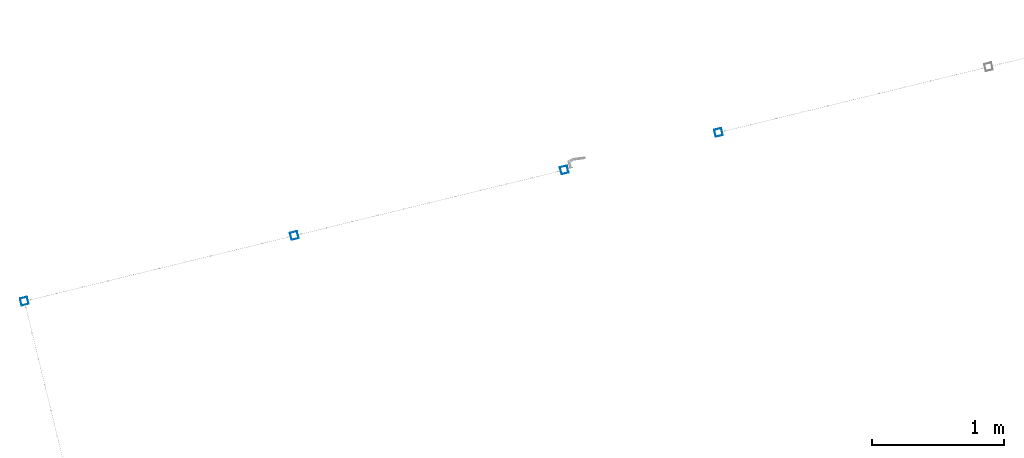
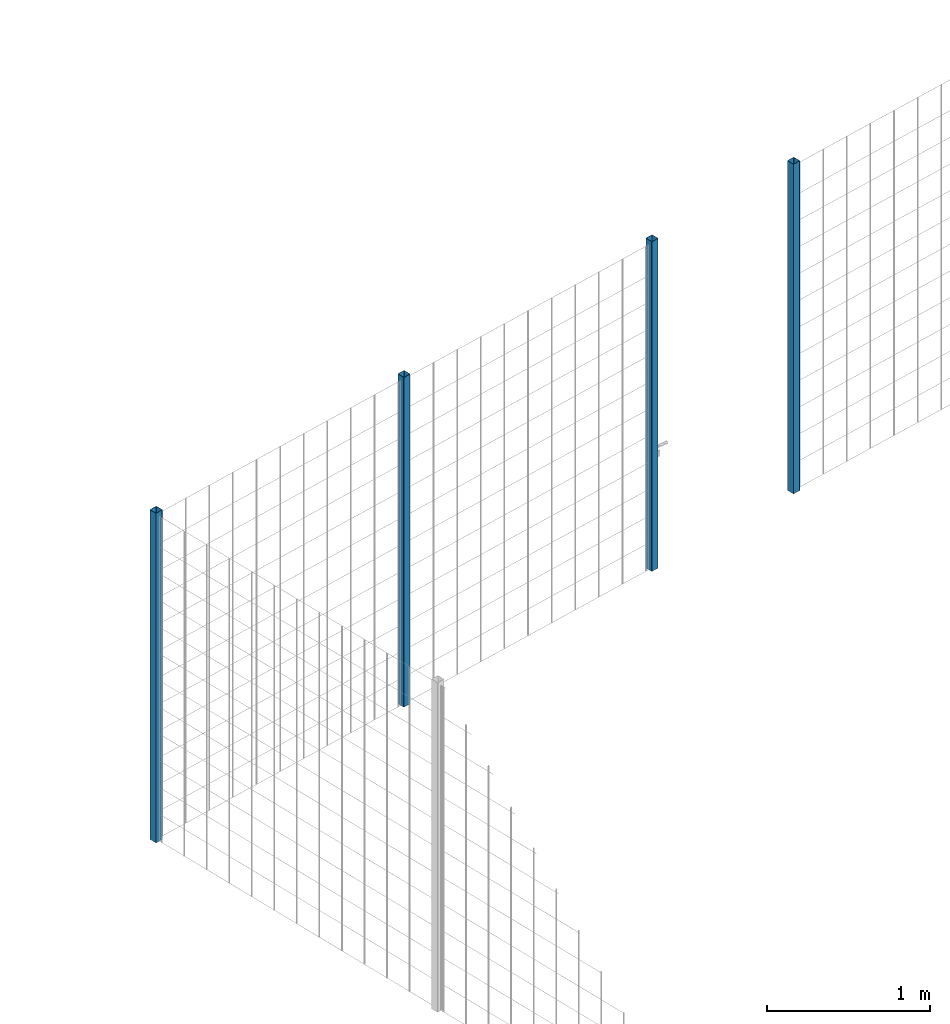
# One storey, part 3 of 10: 4 beams.
"""IFC2X3 building model written with IfcOpenShell, lengths in millimetres."""

from ifc_helpers import new_model, entity, si_unit, converted_unit, derived_unit, direction, frame, frame_2d, origin, place, context, subcontext, project, spatial, polyline, circle_curve, parameter, trimmed, segment, composite_curve, outline, extrude, material, type_object, element, save


model = new_model("IFC2X3")

# Units and contexts
model_context = context("Model", 3, precision=0.01, world=origin(), true_north=direction((6.12303176911189e-17, 1.0)))
body_context = subcontext(model_context, "Body", "Model", "MODEL_VIEW")
ifc_project = project(units=[si_unit("LENGTHUNIT", "METRE", prefix="MILLI"), si_unit("AREAUNIT", "SQUARE_METRE"), si_unit("VOLUMEUNIT", "CUBIC_METRE"), converted_unit("PLANEANGLEUNIT", "DEGREE", entity("IfcRatioMeasure", 0.0174532925199433), si_unit("PLANEANGLEUNIT", "RADIAN"), dimensions=[0, 0, 0, 0, 0, 0, 0]), si_unit("MASSUNIT", "GRAM", prefix="KILO"), derived_unit("MASSDENSITYUNIT", [(si_unit("MASSUNIT", "GRAM", prefix="KILO"), 1), (si_unit("LENGTHUNIT", "METRE"), -3)]), derived_unit("MOMENTOFINERTIAUNIT", [(si_unit("LENGTHUNIT", "METRE"), 4)]), si_unit("TIMEUNIT", "SECOND"), si_unit("FREQUENCYUNIT", "HERTZ"), si_unit("THERMODYNAMICTEMPERATUREUNIT", "DEGREE_CELSIUS"), derived_unit("THERMALTRANSMITTANCEUNIT", [(si_unit("MASSUNIT", "GRAM", prefix="KILO"), 1), (si_unit("THERMODYNAMICTEMPERATUREUNIT", "KELVIN"), -1), (si_unit("TIMEUNIT", "SECOND"), -3)]), derived_unit("VOLUMETRICFLOWRATEUNIT", [(si_unit("LENGTHUNIT", "METRE"), 3), (si_unit("TIMEUNIT", "SECOND"), -1)]), derived_unit("MASSFLOWRATEUNIT", [(si_unit("MASSUNIT", "GRAM", prefix="KILO"), 1), (si_unit("TIMEUNIT", "SECOND"), -1)]), derived_unit("ROTATIONALFREQUENCYUNIT", [(si_unit("TIMEUNIT", "SECOND"), -1)]), si_unit("ELECTRICCURRENTUNIT", "AMPERE"), si_unit("ELECTRICVOLTAGEUNIT", "VOLT"), si_unit("POWERUNIT", "WATT"), si_unit("FORCEUNIT", "NEWTON", prefix="KILO"), si_unit("ILLUMINANCEUNIT", "LUX"), si_unit("LUMINOUSFLUXUNIT", "LUMEN"), si_unit("LUMINOUSINTENSITYUNIT", "CANDELA"), derived_unit("USERDEFINED", [(si_unit("MASSUNIT", "GRAM", prefix="KILO"), -1), (si_unit("LENGTHUNIT", "METRE"), -2), (si_unit("TIMEUNIT", "SECOND"), 3), (si_unit("LUMINOUSFLUXUNIT", "LUMEN"), 1)]), derived_unit("LINEARVELOCITYUNIT", [(si_unit("LENGTHUNIT", "METRE"), 1), (si_unit("TIMEUNIT", "SECOND"), -1)]), si_unit("PRESSUREUNIT", "PASCAL"), derived_unit("USERDEFINED", [(si_unit("LENGTHUNIT", "METRE"), -2), (si_unit("MASSUNIT", "GRAM", prefix="KILO"), 1), (si_unit("TIMEUNIT", "SECOND"), -2)]), derived_unit("LINEARFORCEUNIT", [(si_unit("MASSUNIT", "GRAM", prefix="KILO"), 1), (si_unit("LENGTHUNIT", "METRE"), 1), (si_unit("TIMEUNIT", "SECOND"), -2), (si_unit("LENGTHUNIT", "METRE"), -1)]), derived_unit("PLANARFORCEUNIT", [(si_unit("MASSUNIT", "GRAM", prefix="KILO"), 1), (si_unit("LENGTHUNIT", "METRE"), 1), (si_unit("TIMEUNIT", "SECOND"), -2), (si_unit("LENGTHUNIT", "METRE"), -2)])], contexts=[model_context])

# Site, building, storey
site_placement = place(None, frame((19171.75, -72498.58, 0.0), z_axis=(0.0, 0.0, 1.0), x_axis=(0.971695960795463, 0.236234967296933, 0.0)))
site = spatial("IfcSite", under=ifc_project, at=site_placement, CompositionType="ELEMENT")
building_placement = place(site_placement, origin())
building = spatial("IfcBuilding", under=site, at=building_placement, CompositionType="ELEMENT")
storey_placement = place(building_placement, origin())
storey = spatial("IfcBuildingStorey", under=building, at=storey_placement, Name="01", CompositionType="ELEMENT", Elevation=0.0)

# Beams
ifc_material = material(Name="345")
beam_type = type_object("IfcBeamType", PredefinedType="NOTDEFINED")
beam_1_placement = place(storey_placement, frame((170.9, 5570.9, 0.0), z_axis=(1.0, 0.0, 0.0), x_axis=(0.0, 0.0, -1.0)))
element("IfcBeam", 1, at=beam_1_placement, inside=storey, type_object=beam_type, material=ifc_material, context=body_context, shape_type="SweptSolid", body=[
    extrude(outline(composite_curve([segment(trimmed(circle_curve(frame_2d((24.7, -24.7), x_axis=(1.0, 0.0)), 2.79999999999974), [parameter(269.999999999999)], [parameter(1.32311074748882e-12)], True, "PARAMETER"), True, "CONTINUOUS"), segment(polyline([(27.5, -24.7), (27.5, 24.7)]), True, "CONTINUOUS"), segment(trimmed(circle_curve(frame_2d((24.7, 24.7), x_axis=(1.0, 0.0)), 2.79999999999845), [parameter(1.32311074748882e-12)], [parameter(90.0000000000001)], True, "PARAMETER"), True, "CONTINUOUS"), segment(polyline([(24.7, 27.5), (-24.7, 27.5)]), True, "CONTINUOUS"), segment(trimmed(circle_curve(frame_2d((-24.7, 24.7), x_axis=(1.0, 0.0)), 2.79999999999845), [parameter(90.0000000000001)], [parameter(180.0)], True, "PARAMETER"), True, "CONTINUOUS"), segment(polyline([(-27.5, 24.7), (-27.5, -24.7)]), True, "CONTINUOUS"), segment(trimmed(circle_curve(frame_2d((-24.7, -24.7), x_axis=(1.0, 0.0)), 2.79999999999845), [parameter(180.0)], [parameter(269.999999999998)], True, "PARAMETER"), True, "CONTINUOUS"), segment(polyline([(-24.7, -27.5), (24.7, -27.5)]), True, "CONTINUOUS")], self_intersect=False), holes=[composite_curve([segment(polyline([(23.3, -26.1), (-23.3, -26.1)]), True, "CONTINUOUS"), segment(trimmed(circle_curve(frame_2d((-23.3, -23.3), x_axis=(1.0, 0.0)), 2.79999999999973), [parameter(180.0)], [parameter(270.0)], True, "PARAMETER"), False, "CONTINUOUS"), segment(polyline([(-26.1, -23.3), (-26.1, 23.3)]), True, "CONTINUOUS"), segment(trimmed(circle_curve(frame_2d((-23.3, 23.3), x_axis=(1.0, 0.0)), 2.79999999999973), [parameter(90.0000000000004)], [parameter(180.0)], True, "PARAMETER"), False, "CONTINUOUS"), segment(polyline([(-23.3, 26.1), (23.3, 26.1)]), True, "CONTINUOUS"), segment(trimmed(circle_curve(frame_2d((23.3, 23.3), x_axis=(1.0, 0.0)), 2.79999999999973), [parameter(3.56222124323914e-13)], [parameter(90.0000000000004)], True, "PARAMETER"), False, "CONTINUOUS"), segment(polyline([(26.1, 23.3), (26.1, -23.3)]), True, "CONTINUOUS"), segment(trimmed(circle_curve(frame_2d((23.3, -23.3), x_axis=(1.0, 0.0)), 2.80000000000034), [parameter(270.0)], [parameter(4.57999874130747e-13)], True, "PARAMETER"), False, "CONTINUOUS")], self_intersect=False)]), frame((-2465.98, 29.1, 29.1), z_axis=(1.0, 0.0, 0.0), x_axis=(0.0, 1.0, 0.0)), (0.0, 0.0, 1.0), 2465.97922445826),
])
beam_2_placement = place(storey_placement, frame((2270.9, 5570.9, 0.0), z_axis=(1.0, 0.0, 0.0), x_axis=(0.0, 0.0, -1.0)))
element("IfcBeam", 2, at=beam_2_placement, inside=storey, type_object=beam_type, material=ifc_material, context=body_context, shape_type="SweptSolid", body=[
    extrude(outline(composite_curve([segment(trimmed(circle_curve(frame_2d((24.7, -24.7), x_axis=(1.0, 0.0)), 2.79999999999974), [parameter(269.999999999999)], [parameter(1.32311074748882e-12)], True, "PARAMETER"), True, "CONTINUOUS"), segment(polyline([(27.5, -24.7), (27.5, 24.7)]), True, "CONTINUOUS"), segment(trimmed(circle_curve(frame_2d((24.7, 24.7), x_axis=(1.0, 0.0)), 2.79999999999845), [parameter(1.32311074748882e-12)], [parameter(90.0000000000001)], True, "PARAMETER"), True, "CONTINUOUS"), segment(polyline([(24.7, 27.5), (-24.7, 27.5)]), True, "CONTINUOUS"), segment(trimmed(circle_curve(frame_2d((-24.7, 24.7), x_axis=(1.0, 0.0)), 2.79999999999845), [parameter(90.0000000000001)], [parameter(180.0)], True, "PARAMETER"), True, "CONTINUOUS"), segment(polyline([(-27.5, 24.7), (-27.5, -24.7)]), True, "CONTINUOUS"), segment(trimmed(circle_curve(frame_2d((-24.7, -24.7), x_axis=(1.0, 0.0)), 2.79999999999845), [parameter(180.0)], [parameter(269.999999999998)], True, "PARAMETER"), True, "CONTINUOUS"), segment(polyline([(-24.7, -27.5), (24.7, -27.5)]), True, "CONTINUOUS")], self_intersect=False), holes=[composite_curve([segment(polyline([(23.3, -26.1), (-23.3, -26.1)]), True, "CONTINUOUS"), segment(trimmed(circle_curve(frame_2d((-23.3, -23.3), x_axis=(1.0, 0.0)), 2.79999999999973), [parameter(180.0)], [parameter(270.0)], True, "PARAMETER"), False, "CONTINUOUS"), segment(polyline([(-26.1, -23.3), (-26.1, 23.3)]), True, "CONTINUOUS"), segment(trimmed(circle_curve(frame_2d((-23.3, 23.3), x_axis=(1.0, 0.0)), 2.79999999999973), [parameter(90.0000000000004)], [parameter(180.0)], True, "PARAMETER"), False, "CONTINUOUS"), segment(polyline([(-23.3, 26.1), (23.3, 26.1)]), True, "CONTINUOUS"), segment(trimmed(circle_curve(frame_2d((23.3, 23.3), x_axis=(1.0, 0.0)), 2.79999999999973), [parameter(3.56222124323914e-13)], [parameter(90.0000000000004)], True, "PARAMETER"), False, "CONTINUOUS"), segment(polyline([(26.1, 23.3), (26.1, -23.3)]), True, "CONTINUOUS"), segment(trimmed(circle_curve(frame_2d((23.3, -23.3), x_axis=(1.0, 0.0)), 2.80000000000034), [parameter(270.0)], [parameter(4.57999874130747e-13)], True, "PARAMETER"), False, "CONTINUOUS")], self_intersect=False)]), frame((-2465.98, 29.1, 29.1), z_axis=(1.0, 0.0, 0.0), x_axis=(0.0, 1.0, 0.0)), (0.0, 0.0, 1.0), 2465.97922445826),
])
beam_3_placement = place(storey_placement, frame((4370.9, 5570.9, 0.0), z_axis=(1.0, 0.0, 0.0), x_axis=(0.0, 0.0, -1.0)))
element("IfcBeam", 3, at=beam_3_placement, inside=storey, type_object=beam_type, material=ifc_material, context=body_context, shape_type="SweptSolid", body=[
    extrude(outline(composite_curve([segment(trimmed(circle_curve(frame_2d((24.7, -24.7), x_axis=(1.0, 0.0)), 2.79999999999974), [parameter(269.999999999999)], [parameter(1.32311074748882e-12)], True, "PARAMETER"), True, "CONTINUOUS"), segment(polyline([(27.5, -24.7), (27.5, 24.7)]), True, "CONTINUOUS"), segment(trimmed(circle_curve(frame_2d((24.7, 24.7), x_axis=(1.0, 0.0)), 2.79999999999845), [parameter(1.32311074748882e-12)], [parameter(90.0000000000001)], True, "PARAMETER"), True, "CONTINUOUS"), segment(polyline([(24.7, 27.5), (-24.7, 27.5)]), True, "CONTINUOUS"), segment(trimmed(circle_curve(frame_2d((-24.7, 24.7), x_axis=(1.0, 0.0)), 2.79999999999845), [parameter(90.0000000000001)], [parameter(180.0)], True, "PARAMETER"), True, "CONTINUOUS"), segment(polyline([(-27.5, 24.7), (-27.5, -24.7)]), True, "CONTINUOUS"), segment(trimmed(circle_curve(frame_2d((-24.7, -24.7), x_axis=(1.0, 0.0)), 2.79999999999845), [parameter(180.0)], [parameter(269.999999999998)], True, "PARAMETER"), True, "CONTINUOUS"), segment(polyline([(-24.7, -27.5), (24.7, -27.5)]), True, "CONTINUOUS")], self_intersect=False), holes=[composite_curve([segment(polyline([(23.3, -26.1), (-23.3, -26.1)]), True, "CONTINUOUS"), segment(trimmed(circle_curve(frame_2d((-23.3, -23.3), x_axis=(1.0, 0.0)), 2.79999999999973), [parameter(180.0)], [parameter(270.0)], True, "PARAMETER"), False, "CONTINUOUS"), segment(polyline([(-26.1, -23.3), (-26.1, 23.3)]), True, "CONTINUOUS"), segment(trimmed(circle_curve(frame_2d((-23.3, 23.3), x_axis=(1.0, 0.0)), 2.79999999999973), [parameter(90.0000000000004)], [parameter(180.0)], True, "PARAMETER"), False, "CONTINUOUS"), segment(polyline([(-23.3, 26.1), (23.3, 26.1)]), True, "CONTINUOUS"), segment(trimmed(circle_curve(frame_2d((23.3, 23.3), x_axis=(1.0, 0.0)), 2.79999999999973), [parameter(3.56222124323914e-13)], [parameter(90.0000000000004)], True, "PARAMETER"), False, "CONTINUOUS"), segment(polyline([(26.1, 23.3), (26.1, -23.3)]), True, "CONTINUOUS"), segment(trimmed(circle_curve(frame_2d((23.3, -23.3), x_axis=(1.0, 0.0)), 2.80000000000034), [parameter(270.0)], [parameter(4.57999874130747e-13)], True, "PARAMETER"), False, "CONTINUOUS")], self_intersect=False)]), frame((-2465.98, 29.1, 29.1), z_axis=(1.0, 0.0, 0.0), x_axis=(0.0, 1.0, 0.0)), (0.0, 0.0, 1.0), 2465.97922445826),
])
beam_4_placement = place(storey_placement, frame((5570.9, 5570.9, 0.0), z_axis=(1.0, 0.0, 0.0), x_axis=(0.0, 0.0, -1.0)))
element("IfcBeam", 4, at=beam_4_placement, inside=storey, type_object=beam_type, material=ifc_material, context=body_context, shape_type="SweptSolid", body=[
    extrude(outline(composite_curve([segment(trimmed(circle_curve(frame_2d((24.7, -24.7), x_axis=(1.0, 0.0)), 2.79999999999974), [parameter(269.999999999999)], [parameter(1.32311074748882e-12)], True, "PARAMETER"), True, "CONTINUOUS"), segment(polyline([(27.5, -24.7), (27.5, 24.7)]), True, "CONTINUOUS"), segment(trimmed(circle_curve(frame_2d((24.7, 24.7), x_axis=(1.0, 0.0)), 2.79999999999845), [parameter(1.32311074748882e-12)], [parameter(90.0000000000001)], True, "PARAMETER"), True, "CONTINUOUS"), segment(polyline([(24.7, 27.5), (-24.7, 27.5)]), True, "CONTINUOUS"), segment(trimmed(circle_curve(frame_2d((-24.7, 24.7), x_axis=(1.0, 0.0)), 2.79999999999845), [parameter(90.0000000000001)], [parameter(180.0)], True, "PARAMETER"), True, "CONTINUOUS"), segment(polyline([(-27.5, 24.7), (-27.5, -24.7)]), True, "CONTINUOUS"), segment(trimmed(circle_curve(frame_2d((-24.7, -24.7), x_axis=(1.0, 0.0)), 2.79999999999845), [parameter(180.0)], [parameter(269.999999999998)], True, "PARAMETER"), True, "CONTINUOUS"), segment(polyline([(-24.7, -27.5), (24.7, -27.5)]), True, "CONTINUOUS")], self_intersect=False), holes=[composite_curve([segment(polyline([(23.3, -26.1), (-23.3, -26.1)]), True, "CONTINUOUS"), segment(trimmed(circle_curve(frame_2d((-23.3, -23.3), x_axis=(1.0, 0.0)), 2.79999999999973), [parameter(180.0)], [parameter(270.0)], True, "PARAMETER"), False, "CONTINUOUS"), segment(polyline([(-26.1, -23.3), (-26.1, 23.3)]), True, "CONTINUOUS"), segment(trimmed(circle_curve(frame_2d((-23.3, 23.3), x_axis=(1.0, 0.0)), 2.79999999999973), [parameter(90.0000000000004)], [parameter(180.0)], True, "PARAMETER"), False, "CONTINUOUS"), segment(polyline([(-23.3, 26.1), (23.3, 26.1)]), True, "CONTINUOUS"), segment(trimmed(circle_curve(frame_2d((23.3, 23.3), x_axis=(1.0, 0.0)), 2.79999999999973), [parameter(3.56222124323914e-13)], [parameter(90.0000000000004)], True, "PARAMETER"), False, "CONTINUOUS"), segment(polyline([(26.1, 23.3), (26.1, -23.3)]), True, "CONTINUOUS"), segment(trimmed(circle_curve(frame_2d((23.3, -23.3), x_axis=(1.0, 0.0)), 2.80000000000034), [parameter(270.0)], [parameter(4.57999874130747e-13)], True, "PARAMETER"), False, "CONTINUOUS")], self_intersect=False)]), frame((-2465.98, 29.1, 29.1), z_axis=(1.0, 0.0, 0.0), x_axis=(0.0, 1.0, 0.0)), (0.0, 0.0, 1.0), 2465.97922445826),
])

save(model, "model.ifc")
